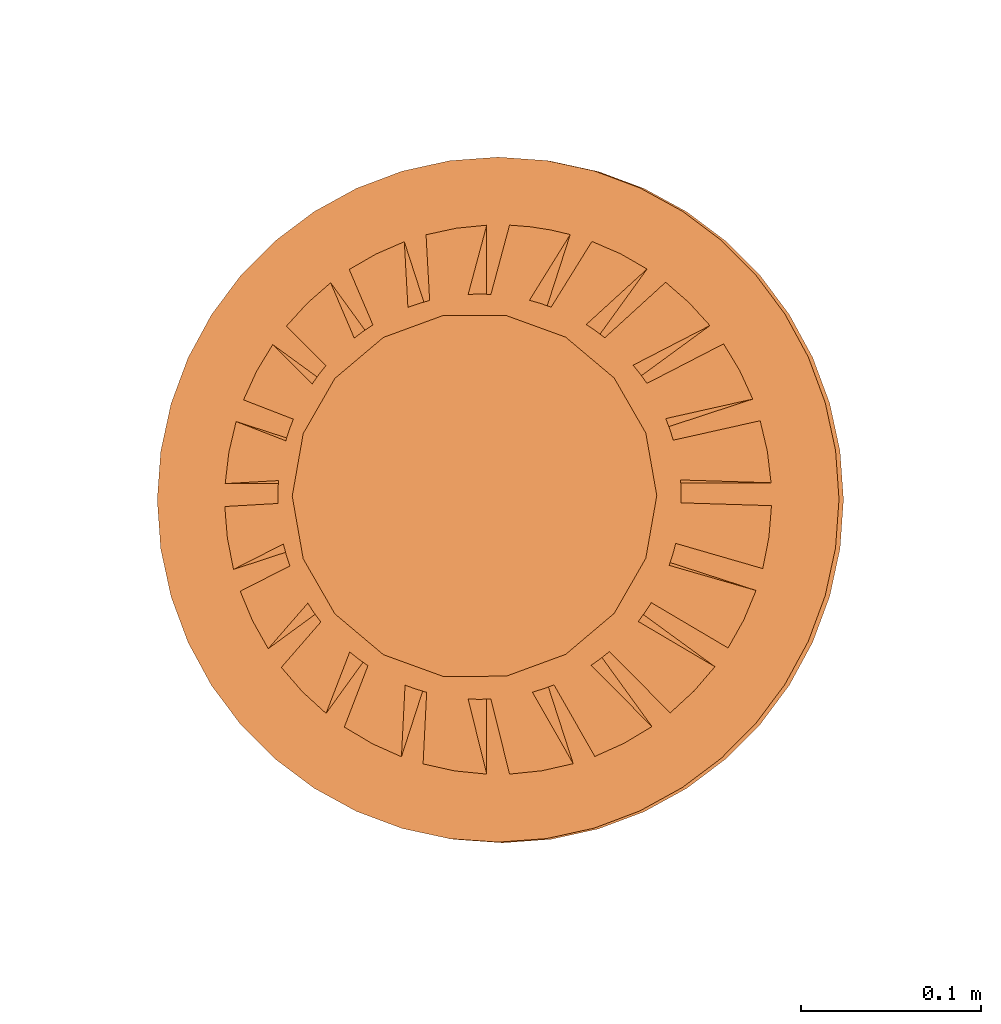
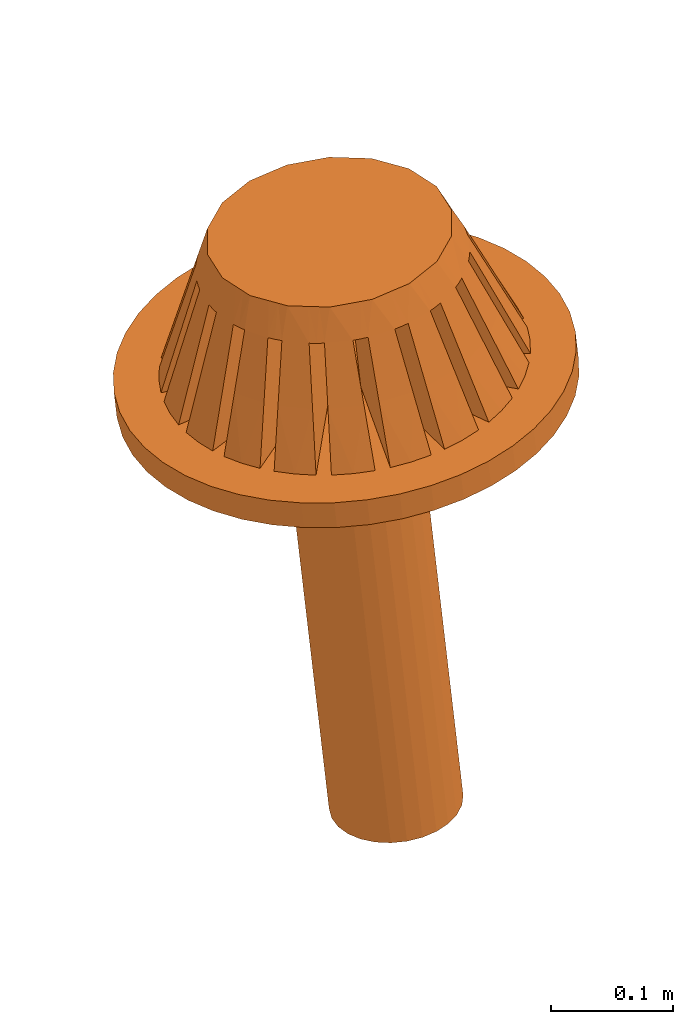
# One storey, part 18 of 18: 1 proxy.
"""IFC2X3 building model written with IfcOpenShell, lengths in centimetres."""

from ifc_helpers import new_model, entity, si_unit, converted_unit, derived_unit, direction, frame, frame_2d, origin, place, context, subcontext, project, spatial, circle, extrude, faceted_brep, source, transform, mapped, type_object, type_shapes, element, save


model = new_model("IFC2X3")

# Units and contexts
model_context = context("Model", 3, precision=0.001, world=origin(), true_north=direction((6.12303176911189e-17, 1.0)))
body_context = subcontext(model_context, "Body", "Model", "MODEL_VIEW")
ifc_project = project(units=[si_unit("LENGTHUNIT", "METRE", prefix="CENTI"), si_unit("AREAUNIT", "SQUARE_METRE"), si_unit("VOLUMEUNIT", "CUBIC_METRE"), converted_unit("PLANEANGLEUNIT", "DEGREE", entity("IfcRatioMeasure", 0.0174532925199433), si_unit("PLANEANGLEUNIT", "RADIAN"), dimensions=[0, 0, 0, 0, 0, 0, 0]), si_unit("MASSUNIT", "GRAM", prefix="KILO"), derived_unit("MASSDENSITYUNIT", [(si_unit("MASSUNIT", "GRAM", prefix="KILO"), 1), (si_unit("LENGTHUNIT", "METRE"), -3)]), si_unit("TIMEUNIT", "SECOND"), si_unit("FREQUENCYUNIT", "HERTZ"), si_unit("THERMODYNAMICTEMPERATUREUNIT", "DEGREE_CELSIUS"), derived_unit("THERMALTRANSMITTANCEUNIT", [(si_unit("MASSUNIT", "GRAM", prefix="KILO"), 1), (si_unit("THERMODYNAMICTEMPERATUREUNIT", "KELVIN"), -1), (si_unit("TIMEUNIT", "SECOND"), -3)]), derived_unit("VOLUMETRICFLOWRATEUNIT", [(si_unit("LENGTHUNIT", "METRE"), 3), (si_unit("TIMEUNIT", "SECOND"), -1)]), si_unit("ELECTRICCURRENTUNIT", "AMPERE"), si_unit("ELECTRICVOLTAGEUNIT", "VOLT"), si_unit("POWERUNIT", "WATT"), si_unit("FORCEUNIT", "NEWTON", prefix="KILO"), si_unit("ILLUMINANCEUNIT", "LUX"), si_unit("LUMINOUSFLUXUNIT", "LUMEN"), si_unit("LUMINOUSINTENSITYUNIT", "CANDELA"), derived_unit("USERDEFINED", [(si_unit("MASSUNIT", "GRAM", prefix="KILO"), -1), (si_unit("LENGTHUNIT", "METRE"), -2), (si_unit("TIMEUNIT", "SECOND"), 3), (si_unit("LUMINOUSFLUXUNIT", "LUMEN"), 1)]), derived_unit("LINEARVELOCITYUNIT", [(si_unit("LENGTHUNIT", "METRE"), 1), (si_unit("TIMEUNIT", "SECOND"), -1)]), si_unit("PRESSUREUNIT", "PASCAL"), derived_unit("USERDEFINED", [(si_unit("LENGTHUNIT", "METRE"), -2), (si_unit("MASSUNIT", "GRAM", prefix="KILO"), 1), (si_unit("TIMEUNIT", "SECOND"), -2)])], contexts=[model_context])

# Site, building, storey
site_placement = place(None, origin())
site = spatial("IfcSite", under=ifc_project, at=site_placement, CompositionType="ELEMENT")
building_placement = place(site_placement, origin())
building = spatial("IfcBuilding", under=site, at=building_placement, CompositionType="ELEMENT")
storey_placement = place(building_placement, frame((0.0, 0.0, 1422.0)))
storey = spatial("IfcBuildingStorey", under=building, at=storey_placement, CompositionType="ELEMENT", Elevation=1422.0)

# Proxy
building_element_proxy_type = type_object("IfcBuildingElementProxyType", PredefinedType="NOTDEFINED")
shared_shape = source(origin(), body_context, "Body", "SolidModel", [
    extrude(circle(Radius=19.0, at=frame_2d((0.0, -3.06953469142194e-14), x_axis=(1.0, 0.0))), origin(), (0.0, 0.0, 1.0), 2.54),
    extrude(circle(Radius=5.5, at=frame_2d((1.92355843129092e-27, -8.88549515937923e-15), x_axis=(1.0, 0.0))), frame((0.0, 0.0, -42.6697612033445)), (0.0, 0.0, 1.0), 42.6697612033443),
    faceted_brep([(-13.467959911725, 7.1324368778196, 2.53999999999981), (-12.5663533924948, 8.62231769391751, 2.53999999999981), (-3.61678062896177, 2.12007247373227, 2.53999999999981), (-14.1911784650603, 5.5559026064833, 2.53999999999981), (9.33544387057166, 12.0460403344576, 2.53999999999981), (10.6372524386057, 10.9135906354124, 2.53999999999981), (11.8047305137619, 9.63877261363989, 2.53999999999981), (2.87029335855172, 3.14752405658845, 2.53999999999981), (-10.6420383482958, 10.9089238604597, 2.53999999999981), (-9.33544387056942, 12.0460403344565, 2.53999999999981), (-2.87029335855033, 3.14752405658845, 2.53999999999981), (-11.804730513759, 9.63877261363881, 2.53999999999981), (5.22880343434972, 14.3149297813465, 2.53999999999981), (6.80772607331836, 13.6349721565766, 2.53999999999981), (8.30000315425692, 12.7815315060165, 2.53999999999981), (1.84284177569554, 3.8940113269999, 2.53999999999981), (0.635000000000694, -3.73200151378123, 2.53999999999981), (4.18391377444547, -14.6544350122444, 2.53999999999981), (2.43086019905985, -15.0448834722211, 2.53999999999981), (0.635000000000694, -15.2267650865205, 2.53999999999981), (-8.57165434960121, -12.6009659038898, 2.53999999999981), (-1.84284177569415, -3.33954993092504, 2.53999999999981), (-5.38954749961934, -14.2551877486548, 2.53999999999981), (-7.0271490791317, -13.5231939947521, 2.53999999999981), (2.87029335855171, -2.59306266051359, 2.53999999999981), (12.0835281839743, -9.28686958168314, 2.53999999999981), (10.9158204820288, -10.634964184435, 2.53999999999981), (9.59111679900109, -11.843482534627, 2.53999999999981), (-12.0835281839714, -9.28686958168203, 2.53999999999981), (-2.87029335855034, -2.5930626605136, 2.53999999999981), (-9.59111679899883, -11.8434825346258, 2.53999999999981), (-10.9091371340833, -10.6418197217289, 2.53999999999981), (3.61678062896316, -1.56561107765742, 2.53999999999981), (14.3750483455808, -5.06118415613312, 2.53999999999981), (13.6893933941843, -6.69761961441146, 2.53999999999981), (12.8148798460614, -8.24842133569207, 2.53999999999981), (-14.3750483455773, -5.06118415613243, 2.53999999999981), (-3.61678062896177, -1.56561107765742, 2.53999999999981), (-12.8148798460584, -8.2484213356909, 2.53999999999981), (-13.6854426476856, -6.70568859528176, 2.53999999999981), (4.00923221181935, -0.357769301962574, 2.53999999999981), (15.2357999831526, -0.357769301962576, 2.53999999999981), (15.091993692444, -2.11880305533537, 2.53999999999981), (14.7465821637106, -3.8465457866775, 2.53999999999981), (-4.18391377444389, -14.6544350122438, 2.53999999999981), (-0.634999999999306, -3.73200151378122, 2.53999999999981), (-0.634999999999306, -15.2267650865204, 2.53999999999981), (-2.43017839604844, -15.0449936179264, 2.53999999999981), (1.84284177569554, -3.33954993092504, 2.53999999999981), (8.57165434960338, -12.6009659038909, 2.53999999999981), (7.02577035383633, -13.5239103418815, 2.53999999999981), (5.38954749962098, -14.2551877486556, 2.53999999999981), (-15.2357999831488, -0.357769301962569, 2.53999999999981), (-4.00923221181796, -0.357769301962572, 2.53999999999981), (-14.7465821637071, -3.84654578667679, 2.53999999999981), (-15.0914467339494, -2.12269533290175, 2.53999999999981), (14.6045478126464, 4.35485742454993, 2.53999999999981), (15.0066588257202, 2.65665031354838, 2.53999999999981), (15.2126735044702, 0.912230698037424, 2.53999999999981), (4.00923221181935, 0.912230698037426, 2.53999999999981), (-6.80575831032103, 13.6359544521607, 2.53999999999981), (-5.22880343434807, 14.3149297813457, 2.53999999999981), (-1.84284177569415, 3.89401132699989, 2.53999999999981), (-8.30000315425477, 12.7815315060154, 2.53999999999981), (0.635000000000694, 15.2267650865154, 2.53999999999981), (1.77660370807615, 15.1360919415938, 2.53999999999981), (2.90596513611333, 14.9603798958325, 2.53999999999981), (4.01875360813548, 14.7005856834699, 2.53999999999981), (0.635000000000694, 4.28646290985607, 2.53999999999981), (-15.0074040021538, 2.65243758005144, 2.53999999999981), (-14.6045478126429, 4.35485742454923, 2.53999999999981), (-4.00923221181796, 0.912230698037428, 2.53999999999981), (-15.2126735044665, 0.91223069803743, 2.53999999999981), (12.5663533924978, 8.62231769391866, 2.53999999999981), (13.4643458163018, 7.13925708593345, 2.53999999999981), (14.1911784650638, 5.55590260648399, 2.53999999999981), (3.61678062896316, 2.12007247373227, 2.53999999999981), (-2.34556631288643, 15.0584168713636, 2.53999999999981), (-0.634999999999306, 15.2267650865153, 2.53999999999981), (-0.634999999999306, 4.28646290985609, 2.53999999999981), (-4.01875360813389, 14.7005856834693, 2.53999999999981), (-0.634999999999306, -13.2254069753517, 7.78831335316191), (-0.634999999999306, -3.73200151378123, 13.0363510851103), (-0.634999999999306, -11.223440895929, 13.0363510851103), (-0.634999999999306, 13.2254069753467, 7.78831335316191), (-0.634999999999306, 11.223440895924, 13.0363510851103), (-0.634999999999306, 4.28646290985609, 13.0363510851103), (0.635000000000694, 13.2254069753468, 7.78831335316191), (0.635000000000694, 4.28646290985607, 13.0363510851103), (0.635000000000694, 11.2234408959241, 13.0363510851103), (0.635000000000693, -13.2254069753518, 7.78831335316191), (0.635000000000693, -11.2234408959292, 13.0363510851103), (0.635000000000695, -3.73200151378123, 13.0363510851103), (7.395825950438, -10.9825769537031, 7.78825156071356), (1.84284177569554, -3.33954993092504, 13.0363510851103), (6.21980036170794, -9.36391659536358, 13.0363510851103), (-8.15961547140403, 10.4276513842687, 7.78825156071356), (-6.98358988267396, 8.80899102592914, 13.0363510851103), (-2.87029335855033, 3.14752405658845, 13.0363510851103), (-7.12293375046627, 11.1614344595012, 7.78839367121062), (-1.84284177569415, 3.89401132699989, 13.0363510851103), (-5.94529897297529, 9.5405592428445, 13.0363510851103), (8.4140473952126, -10.2233854881127, 7.78839367121062), (7.23641261772162, -8.60251027145605, 13.0363510851103), (2.87029335855172, -2.5930626605136, 13.0363510851103), (10.4653622527995, -8.11120321531528, 7.78823305884087), (8.84699094962167, -6.93538763745311, 13.0363510851103), (-10.9481874613201, 7.44665132754965, 7.78823305884087), (-9.32981615814222, 6.27083574968748, 13.0363510851103), (-3.61678062896178, 2.12007247373227, 13.0363510851103), (-10.1842131428712, 8.46139782631736, 7.78842875148637), (-8.56279262952923, 7.28336686759414, 13.0363510851103), (11.1943624751735, -7.07104654837063, 7.78842875148637), (9.57294196183155, -5.8930155896474, 13.0363510851103), (3.61678062896316, -1.56561107765742, 13.0363510851103), (12.4729292779123, -4.44314820646743, 7.78822254411232), (10.5706129058111, -3.82504814870544, 13.0363510851103), (-12.7024287449743, 3.73682147488353, 7.78822254411232), (-10.8001123728732, 3.11872141712155, 13.0363510851103), (-4.00923221181796, 0.912230698037428, 13.0363510851103), (-12.2858092879303, 4.9368106322387, 7.78845268437236), (-10.3792782066206, 4.31734113244095, 13.0363510851103), (12.8412129865807, -3.22745381243289, 7.78845268437236), (10.934681905271, -2.60798431263514, 13.0363510851103), (4.00923221181934, -0.357769301962574, 13.0363510851103), (13.2358439831053, -0.357769301962576, 7.78821916765944), (11.2356954244486, -0.357769301962575, 13.0363510851103), (-13.2358439831016, -0.35776930196257, 7.78821916765943), (-11.2356954244448, -0.35776930196257, 13.0363510851103), (-4.00923221181795, -0.357769301962571, 13.0363510851103), (-13.209124060714, 0.91223069803743, 7.78846118750995), (-11.2043154943918, 0.912230698037429, 13.0363510851103), (13.2091240607178, 0.912230698037424, 7.78846118750995), (11.2043154943956, 0.912230698037424, 13.0363510851103), (4.00923221181935, 0.912230698037428, 13.0363510851103), (12.7024287449779, 3.73682147488424, 7.78822254411231), (10.8001123728767, 3.11872141712226, 13.0363510851103), (-12.4729292779088, -4.44314820646674, 7.78822254411232), (-10.5706129058076, -3.82504814870476, 13.0363510851103), (-3.61678062896177, -1.56561107765742, 13.0363510851103), (-12.8412129865771, -3.22745381243218, 7.78845268437236), (-10.9346819052674, -2.60798431263443, 13.0363510851103), (12.2858092879338, 4.93681063223938, 7.78845268437236), (10.3792782066241, 4.31734113244163, 13.0363510851103), (3.61678062896317, 2.12007247373227, 13.0363510851103), (10.9481874613231, 7.44665132755081, 7.78823305884087), (9.32981615814522, 6.27083574968865, 13.0363510851103), (-10.4653622527966, -8.11120321531418, 7.78823305884087), (-8.84699094961877, -6.93538763745202, 13.0363510851103), (-2.87029335855034, -2.59306266051361, 13.0363510851103), (-11.1943624751705, -7.07104654836945, 7.78842875148637), (-9.57294196182853, -5.89301558964622, 13.0363510851103), (10.1842131428741, 8.46139782631843, 7.78842875148638), (8.56279262953209, 7.2833668675952, 13.0363510851103), (2.87029335855172, 3.14752405658845, 13.0363510851103), (8.15961547140628, 10.4276513842699, 7.78825156071356), (6.98358988267623, 8.80899102593034, 13.0363510851103), (-7.39582595043583, -10.982576953702, 7.78825156071356), (-6.21980036170578, -9.36391659536252, 13.0363510851103), (-1.84284177569415, -3.33954993092504, 13.0363510851103), (-8.41404739521033, -10.2233854881115, 7.78839367121062), (-7.23641261771934, -8.60251027145481, 13.0363510851103), (7.12293375046841, 11.1614344595022, 7.78839367121062), (5.94529897297742, 9.54055924284552, 13.0363510851103), (1.84284177569554, 3.8940113269999, 13.0363510851103), (4.61050960133581, 12.4120170303426, 7.78827857144105), (3.99207528530712, 10.5086719170768, 13.0363510851103), (-3.56561994142997, -12.7515222612399, 7.78827857144105), (-2.94718562540128, -10.8481771479742, 13.0363510851103), (-4.7709107140866, -12.3512194983297, 7.78835325421778), (-4.15203171408524, -10.446505788522, 13.0363510851103), (3.40011682260275, 12.7966174331448, 7.78835325421778), (2.78123782260139, 10.8919037233371, 13.0363510851103), (3.56561994143155, -12.7515222612405, 7.78827857144105), (2.94718562540286, -10.8481771479748, 13.0363510851103), (-4.61050960133415, 12.4120170303418, 7.78827857144105), (-3.99207528530546, 10.508671917076, 13.0363510851103), (-3.40011682260117, 12.7966174331442, 7.78835325421778), (-2.78123782259981, 10.8919037233365, 13.0363510851103), (4.77091071408826, -12.3512194983305, 7.78835325421777), (4.15203171408689, -10.4465057885229, 13.0363510851103), (-2.59319911382011, 9.70393960356297, 15.8749999999998), (-3.4221327425461, 9.40223243652444, 15.8749999999998), (-5.07999999999809, 8.79881810244738, 15.8749999999998), (-5.7557528855203, 8.23179410543872, 15.8749999999998), (-6.4315057710425, 7.66477010843005, 15.8749999999998), (-7.78301154208691, 6.53072211441273, 15.8749999999998), (-8.22407791336091, 5.76677274985612, 15.8749999999998), (-8.66514428463491, 5.00282338529952, 15.8749999999998), (-9.10621065590892, 4.23887402074291, 15.8749999999998), (-9.54727702718292, 3.4749246561863, 15.8749999999998), (-9.70045777038672, 2.60619349213911, 15.8749999999998), (-9.85363851359051, 1.73746232809191, 15.8749999999998), (-10.0068192567943, 0.868731164044709, 15.8749999999998), (-10.1599999999981, 0.0, 15.8749999999998), (-9.85363851359053, -1.73746232809688, 15.8749999999998), (-9.70045777038674, -2.60619349214408, 15.8749999999998), (-9.54727702718295, -3.47492465619127, 15.8749999999998), (-8.66514428463495, -5.0028233853045, 15.8749999999998), (-8.22407791336095, -5.76677274986111, 15.8749999999998), (-7.78301154208695, -6.53072211441772, 15.8749999999998), (-6.43150577104255, -7.66477010843505, 15.8749999999998), (-5.75575288552035, -8.23179410544372, 15.8749999999998), (-5.07999999999815, -8.79881810245239, 15.8749999999998), (-3.42213274254616, -9.40223243652946, 15.8749999999998), (-2.59319911382017, -9.70393960356799, 15.8749999999998), (-1.76426548509418, -10.0056467706065, 15.8749999999998), (-0.88213274254617, -10.0056467706065, 15.8749999999998), (0.0, -10.0056467706065, 15.8749999999998), (0.882132742549835, -10.0056467706065, 15.8749999999998), (1.76426548509784, -10.0056467706065, 15.8749999999998), (2.59319911382384, -9.70393960356802, 15.8749999999998), (3.42213274254983, -9.40223243652949, 15.8749999999998), (5.08000000000183, -8.79881810245243, 15.8749999999998), (5.75575288552403, -8.23179410544377, 15.8749999999998), (6.43150577104623, -7.66477010843511, 15.8749999999998), (7.78301154209065, -6.53072211441779, 15.8749999999998), (8.22407791336465, -5.76677274986118, 15.8749999999998), (8.66514428463866, -5.00282338530458, 15.8749999999998), (9.54727702718667, -3.47492465619137, 15.8749999999998), (9.70045777039047, -2.60619349214417, 15.8749999999998), (9.85363851359427, -1.73746232809697, 15.8749999999998), (10.1600000000019, 0.0, 15.8749999999998), (10.0068192567981, 0.86873116404468, 15.8749999999998), (9.85363851359429, 1.73746232809188, 15.8749999999998), (9.70045777039049, 2.60619349213907, 15.8749999999998), (9.5472770271867, 3.47492465618627, 15.8749999999998), (9.1062106559127, 4.23887402074288, 15.8749999999998), (8.6651442846387, 5.00282338529949, 15.8749999999998), (8.2240779133647, 5.7667727498561, 15.8749999999998), (7.78301154209069, 6.53072211441271, 15.8749999999998), (6.43150577104629, 7.66477010843004, 15.8749999999998), (5.75575288552409, 8.2317941054387, 15.8749999999998), (5.08000000000188, 8.79881810244737, 15.8749999999998), (3.42213274254989, 9.40223243652443, 15.8749999999998), (2.5931991138239, 9.70393960356297, 15.8749999999998), (1.7642654850979, 10.0056467706015, 15.8749999999998), (0.8821327425499, 10.0056467706015, 15.8749999999998), (0.0, 10.0056467706015, 15.8749999999998), (-0.882132742546106, 10.0056467706015, 15.8749999999998), (-1.76426548509411, 10.0056467706015, 15.8749999999998), (10.7698531709191, -3.22166311417828, 13.0363510851103), (11.2399663130641, -0.178907310034193, 13.0363510851103), (11.2413900628169, 0.0, 13.0363510851103), (3.5552857379653, -10.6643702986086, 13.0363510851103), (9.22470145788588, -6.42446367857287, 13.0363510851103), (6.73886873551225, -8.99758293709833, 13.0363510851103), (-6.73886873550998, -8.99758293709723, 13.0363510851103), (0.0, -11.2413900628176, 13.0363510851103), (-3.55528573796362, -10.6643702986079, 13.0363510851103), (-10.7698531709156, -3.22166311417766, 13.0363510851103), (-11.2399663130604, -0.178907310034141, 13.0363510851103), (-11.2413900628132, 0.0, 13.0363510851103), (-9.22470145788288, -6.42446367857179, 13.0363510851103), (-8.96061756372554, 6.78794397597258, 13.0363510851103), (-10.6066403085603, 3.72398065369879, 13.0363510851103), (-11.2321175965086, 0.456491886581969, 13.0363510851103), (-3.39207300463341, 10.7174013303379, 13.0363510851103), (-6.47478492109452, 9.18945105922292, 13.0363510851103), (8.96061756372843, 6.78794397597374, 13.0363510851103), (3.39207300463496, 10.7174013303386, 13.0363510851103), (0.0, 11.2413900628125, 13.0363510851103), (10.6066403085638, 3.72398065369954, 13.0363510851103), (11.2321175965123, 0.45649188658195, 13.0363510851103), (6.47478492109666, 9.18945105922407, 13.0363510851103)], [[[0, 1, 2, 3]], [[4, 5, 6, 7]], [[8, 9, 10, 11]], [[12, 13, 14, 15]], [[16, 17, 18, 19]], [[20, 21, 22, 23]], [[24, 25, 26, 27]], [[28, 29, 30, 31]], [[32, 33, 34, 35]], [[36, 37, 38, 39]], [[40, 41, 42, 43]], [[44, 45, 46, 47]], [[48, 49, 50, 51]], [[52, 53, 54, 55]], [[56, 57, 58, 59]], [[60, 61, 62, 63]], [[64, 65, 66, 67, 68]], [[69, 70, 71, 72]], [[73, 74, 75, 76]], [[77, 78, 79, 80]], [[81, 46, 45, 82, 83]], [[84, 85, 86, 79, 78]], [[87, 64, 68, 88, 89]], [[90, 91, 92, 16, 19]], [[93, 49, 48, 94, 95]], [[96, 97, 98, 10, 9]], [[99, 63, 62, 100, 101]], [[102, 103, 104, 24, 27]], [[105, 25, 24, 104, 106]], [[107, 108, 109, 2, 1]], [[110, 11, 10, 98, 111]], [[112, 113, 114, 32, 35]], [[115, 33, 32, 114, 116]], [[117, 118, 119, 71, 70]], [[120, 3, 2, 109, 121]], [[122, 123, 124, 40, 43]], [[125, 41, 40, 124, 126]], [[127, 128, 129, 53, 52]], [[130, 72, 71, 119, 131]], [[132, 133, 134, 59, 58]], [[135, 56, 59, 134, 136]], [[137, 138, 139, 37, 36]], [[140, 54, 53, 129, 141]], [[142, 143, 144, 76, 75]], [[145, 73, 76, 144, 146]], [[147, 148, 149, 29, 28]], [[150, 38, 37, 139, 151]], [[152, 153, 154, 7, 6]], [[155, 4, 7, 154, 156]], [[157, 158, 159, 21, 20]], [[160, 30, 29, 149, 161]], [[162, 163, 164, 15, 14]], [[165, 12, 15, 164, 166]], [[167, 168, 82, 45, 44]], [[169, 22, 21, 159, 170]], [[171, 172, 88, 68, 67]], [[173, 17, 16, 92, 174]], [[175, 176, 100, 62, 61]], [[177, 80, 79, 86, 178]], [[179, 180, 94, 48, 51]], [[181, 182, 183, 184, 185, 186, 187, 188, 189, 190, 191, 192, 193, 194, 195, 196, 197, 198, 199, 200, 201, 202, 203, 204, 205, 206, 207, 208, 209, 210, 211, 212, 213, 214, 215, 216, 217, 218, 219, 220, 221, 222, 223, 224, 225, 226, 227, 228, 229, 230, 231, 232, 233, 234, 235, 236, 237, 238, 239, 240]], [[220, 241, 123]], [[241, 220, 219]], [[219, 218, 116]], [[219, 116, 241]], [[216, 106, 217]], [[115, 116, 113]], [[222, 126, 242]], [[242, 243, 222]], [[112, 115, 113]], [[126, 123, 125]], [[126, 222, 221]], [[123, 122, 125]], [[213, 95, 214]], [[211, 210, 174]], [[213, 212, 180]], [[174, 210, 91]], [[244, 212, 211]], [[209, 208, 91, 210]], [[83, 208, 207, 206]], [[216, 103, 106]], [[245, 217, 106]], [[246, 215, 214]], [[103, 215, 246]], [[213, 180, 95]], [[105, 106, 103]], [[95, 180, 93]], [[113, 218, 217]], [[173, 174, 91]], [[125, 122, 42]], [[25, 105, 26]], [[112, 34, 115]], [[26, 105, 102]], [[43, 42, 122]], [[42, 41, 125]], [[115, 34, 33]], [[35, 34, 112]], [[180, 179, 93]], [[50, 93, 179]], [[18, 173, 90]], [[90, 173, 91]], [[18, 90, 19]], [[93, 50, 49]], [[51, 50, 179]], [[173, 18, 17]], [[102, 27, 26]], [[102, 105, 103]], [[204, 203, 170]], [[158, 202, 247]], [[161, 201, 200]], [[161, 200, 148]], [[180, 212, 244]], [[201, 247, 202]], [[206, 168, 83]], [[248, 208, 83]], [[167, 83, 168]], [[170, 249, 204]], [[205, 204, 249]], [[157, 170, 158]], [[203, 158, 170]], [[250, 196, 141]], [[91, 208, 248]], [[126, 221, 123]], [[200, 199, 148]], [[198, 151, 199]], [[116, 218, 113]], [[138, 197, 250]], [[195, 194, 128]], [[138, 151, 198]], [[138, 198, 197]], [[137, 151, 138]], [[197, 196, 250]], [[127, 140, 141]], [[244, 211, 174]], [[141, 195, 128]], [[194, 251, 128]], [[127, 141, 128]], [[194, 252, 251]], [[161, 148, 147]], [[158, 203, 202]], [[83, 167, 81]], [[47, 81, 167]], [[123, 221, 220]], [[157, 169, 170]], [[30, 160, 31]], [[169, 157, 23]], [[247, 201, 161]], [[113, 217, 245]], [[81, 47, 46]], [[167, 44, 47]], [[148, 199, 253]], [[22, 169, 23]], [[157, 20, 23]], [[246, 214, 95]], [[31, 147, 28]], [[147, 31, 160]], [[141, 196, 195]], [[151, 137, 150]], [[140, 127, 55]], [[39, 150, 137]], [[205, 249, 168]], [[160, 161, 147]], [[140, 55, 54]], [[38, 150, 39]], [[39, 137, 36]], [[168, 206, 205]], [[127, 52, 55]], [[199, 151, 253]], [[103, 216, 215]], [[191, 190, 118, 192]], [[188, 121, 190, 189]], [[108, 187, 254]], [[107, 121, 108]], [[187, 186, 254]], [[255, 190, 121]], [[252, 194, 256]], [[118, 131, 192]], [[256, 194, 193]], [[117, 131, 118]], [[130, 131, 117]], [[118, 190, 255]], [[183, 101, 184]], [[181, 240, 178]], [[182, 181, 257]], [[238, 85, 240, 239]], [[237, 236, 89, 238]], [[84, 178, 85]], [[240, 85, 178]], [[97, 185, 184]], [[111, 186, 185]], [[96, 111, 97]], [[183, 176, 101]], [[258, 184, 101]], [[175, 101, 176]], [[257, 176, 182]], [[186, 111, 254]], [[120, 121, 107]], [[107, 0, 120]], [[11, 110, 8]], [[8, 110, 96]], [[117, 70, 69]], [[72, 130, 69]], [[120, 0, 3]], [[107, 1, 0]], [[69, 130, 117]], [[96, 110, 111]], [[99, 101, 175]], [[175, 60, 99]], [[77, 177, 84]], [[84, 177, 178]], [[77, 84, 78]], [[99, 60, 63]], [[61, 60, 175]], [[177, 77, 80]], [[96, 9, 8]], [[166, 234, 233]], [[231, 153, 156]], [[153, 231, 230]], [[153, 230, 259]], [[176, 183, 182]], [[231, 156, 232]], [[260, 235, 234]], [[172, 89, 236]], [[172, 236, 235]], [[87, 89, 172]], [[233, 163, 166]], [[235, 260, 172]], [[85, 238, 261]], [[165, 166, 163]], [[232, 163, 233]], [[153, 155, 156]], [[89, 261, 238]], [[228, 143, 146]], [[259, 230, 229]], [[145, 146, 143]], [[131, 193, 192]], [[262, 226, 136]], [[223, 222, 263]], [[226, 262, 143]], [[226, 143, 228, 227]], [[259, 229, 146]], [[136, 226, 225, 224]], [[97, 184, 258]], [[133, 135, 136]], [[223, 263, 133]], [[222, 243, 263]], [[132, 135, 133]], [[121, 188, 108]], [[145, 143, 142]], [[171, 65, 87]], [[171, 87, 172]], [[133, 224, 223]], [[257, 181, 178]], [[165, 162, 13]], [[163, 162, 165]], [[162, 14, 13]], [[171, 66, 65]], [[65, 64, 87]], [[67, 66, 171]], [[165, 13, 12]], [[155, 152, 5]], [[232, 156, 264]], [[5, 152, 6]], [[155, 5, 4]], [[136, 224, 133]], [[260, 234, 166]], [[111, 185, 97]], [[145, 142, 74]], [[163, 232, 264]], [[256, 193, 131]], [[74, 73, 145]], [[142, 75, 74]], [[135, 57, 56]], [[135, 132, 57]], [[108, 188, 187]], [[132, 58, 57]], [[146, 229, 228]], [[153, 152, 155]], [[144, 143, 262, 136, 134, 133, 263, 243, 242, 126, 124, 123, 241, 116, 114, 113, 245, 106, 104, 103, 246, 95, 94, 180, 244, 174, 92, 91, 248, 83, 82, 168, 249, 170, 159, 158, 247, 161, 149, 148, 253, 151, 139, 138, 250, 141, 129, 128, 251, 252, 256, 131, 119, 118, 255, 121, 109, 108, 254, 111, 98, 97, 258, 101, 100, 176, 257, 178, 86, 85, 261, 89, 88, 172, 260, 166, 164, 163, 264, 156, 154, 153, 259, 146]]]),
])
type_shapes(building_element_proxy_type, [shared_shape])
proxy_placement = place(storey_placement, frame((5804.14967959585, 6341.70192572417, -614.081351943929), z_axis=(-0.0982812914495915, 0.0155492073756272, 0.995037190209989), x_axis=(0.995158674659976, 0.00153563066956797, 0.0982692937160242)))
element("IfcBuildingElementProxy", 1, at=proxy_placement, inside=storey, type_object=building_element_proxy_type, context=body_context, shape_type="MappedRepresentation", body=[
    mapped(shared_shape, transform((0.0, 0.0, 0.0), scale=1.0)),
])

save(model, "model.ifc")
